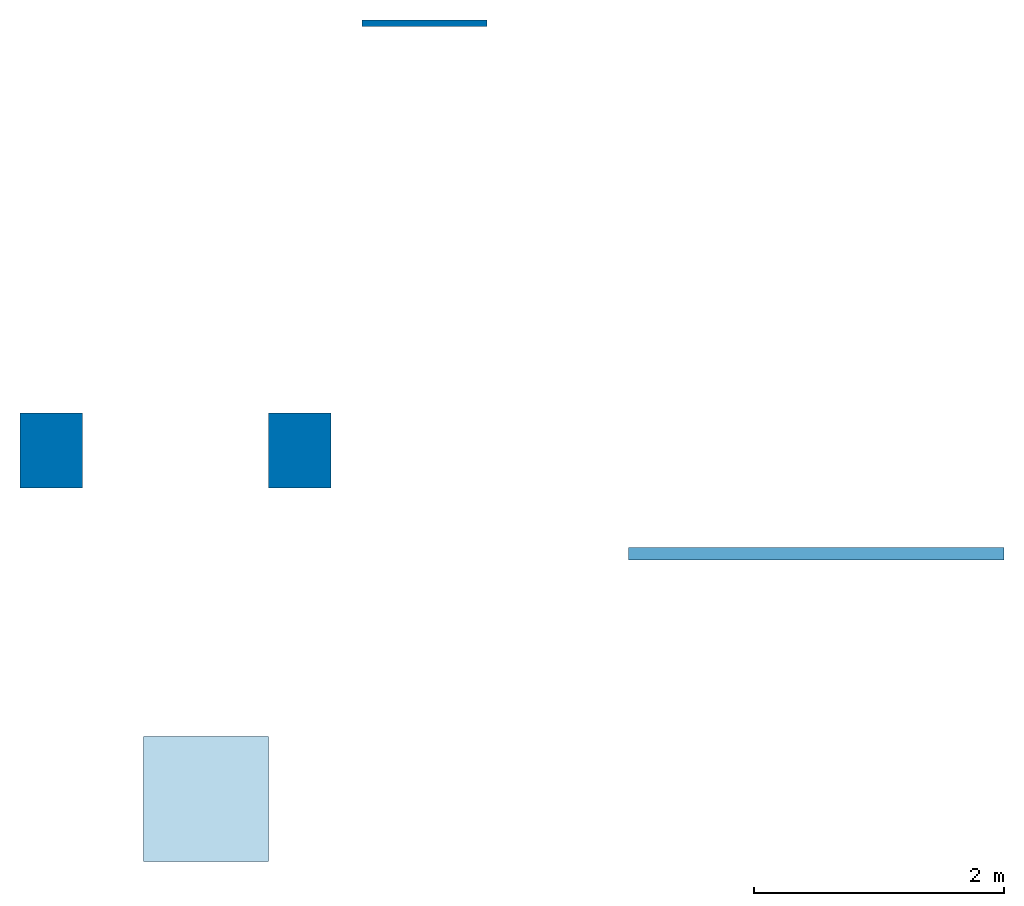
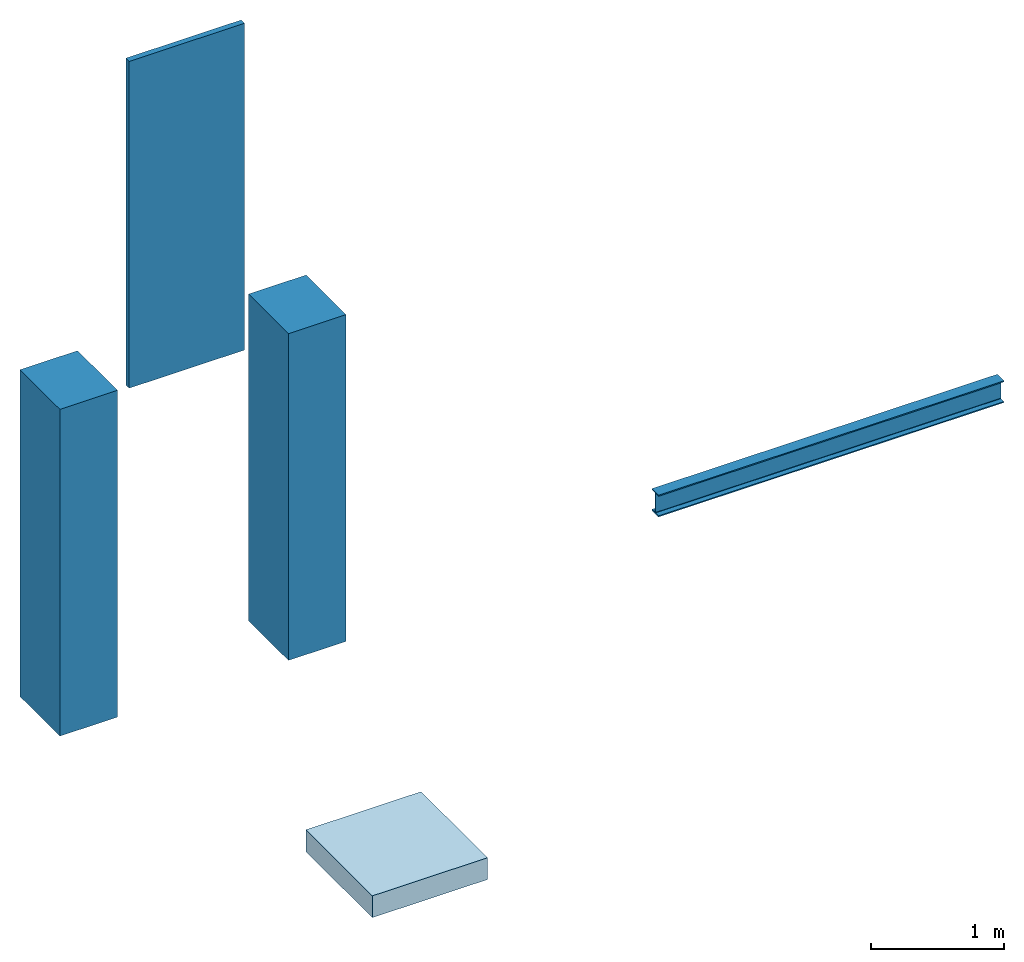
# One storey: 2 columns, 1 beam, 1 slab, 1 wall.
"""IFC4 building model written with IfcOpenShell, lengths in millimetres."""

from ifc_helpers import new_model, entity, si_unit, converted_unit, frame, origin_with_axes, origin_2d_with_axis, place, context, subcontext, project, spatial, indexed_curve, rectangle, i_section, outline, extrude, material, layer, layer_set, layer_usage, material_profile, profile_set, profile_usage, type_object, element, save


model = new_model("IFC4")

# Units and contexts
model_context = context("Model", 3, precision=1e-05, world=origin_with_axes())
plan_context = context("Plan", 2, precision=1e-05, world=origin_2d_with_axis())
body_context = subcontext(model_context, "Body", "Model", "MODEL_VIEW")
ifc_project = project(units=[si_unit("VOLUMEUNIT", "CUBIC_METRE"), si_unit("LENGTHUNIT", "METRE", prefix="MILLI"), converted_unit("PLANEANGLEUNIT", "degree", entity("IfcReal", 0.0174532925199433), si_unit("PLANEANGLEUNIT", "RADIAN"), dimensions=[0, 0, 0, 0, 0, 0, 0]), si_unit("AREAUNIT", "SQUARE_METRE")], contexts=[model_context, plan_context])

# Site, building, storey
site_placement = place(None, origin_with_axes())
site = spatial("IfcSite", under=ifc_project, at=site_placement)
building_placement = place(site_placement, origin_with_axes())
building = spatial("IfcBuilding", under=site, at=building_placement, Name="Building")
storey_placement = place(building_placement, origin_with_axes())
storey = spatial("IfcBuildingStorey", under=building, at=storey_placement, Name="Storey")

# Columns
ifc_material = material(Name="Green")
ifc_material_profile_1 = material_profile(ifc_material, rectangle(XDim=500.0, YDim=600.0))
ifc_profile_set_1 = profile_set([ifc_material_profile_1])
ifc_profile_usage_1 = profile_usage(ifc_profile_set_1, cardinal=5)
column_type = type_object("IfcColumnType", Name="C1", PredefinedType="NOTDEFINED", material=ifc_profile_set_1)
column_1_placement = place(storey_placement, frame((-730.887413024902, 780.275821685791, 0.0), z_axis=(0.0, 0.0, 1.0), x_axis=(1.0, 0.0, 0.0)))
element("IfcColumn", 1, at=column_1_placement, inside=storey, type_object=column_type, material=ifc_profile_usage_1, Name="Column", context=body_context, shape_type="SweptSolid", body=[
    extrude(rectangle(XDim=500.0, YDim=600.0), origin_with_axes(), (0.0, 0.0, 1.0), 3000.0),
])
ifc_profile_usage_2 = profile_usage(ifc_profile_set_1, cardinal=5)
column_2_placement = place(storey_placement, frame((-2715.92807769775, 780.275821685791, 0.0), z_axis=(0.0, 0.0, 1.0), x_axis=(1.0, 0.0, 0.0)))
element("IfcColumn", 2, at=column_2_placement, inside=storey, type_object=column_type, material=ifc_profile_usage_2, Name="Column", context=body_context, shape_type="SweptSolid", body=[
    extrude(rectangle(XDim=500.0, YDim=600.0), origin_with_axes(), (0.0, 0.0, 1.0), 3000.0),
])

# Beam
ifc_material_profile_2 = material_profile(ifc_material, i_section(OverallWidth=100.0, OverallDepth=200.0, WebThickness=5.0, FlangeThickness=10.0, FilletRadius=5.0))
ifc_profile_set_2 = profile_set([ifc_material_profile_2])
ifc_profile_usage_3 = profile_usage(ifc_profile_set_2, cardinal=5)
beam_type = type_object("IfcBeamType", Name="B1", PredefinedType="NOTDEFINED", material=ifc_profile_set_2)
beam_placement = place(storey_placement, frame((1899.37174320221, -46.2498664855957, 757.964909076691), z_axis=(0.999999999999994, -7.54979012640429e-08, 7.54979012640429e-08), x_axis=(7.54979012640431e-08, 0.999999999999997, 7.16093850883224e-15)))
element("IfcBeam", 3, at=beam_placement, inside=storey, type_object=beam_type, material=ifc_profile_usage_3, Name="Beam", context=body_context, shape_type="SweptSolid", body=[
    extrude(i_section(OverallWidth=100.0, OverallDepth=200.0, WebThickness=5.0, FlangeThickness=10.0, FilletRadius=5.0), origin_with_axes(), (0.0, 0.0, 1.0), 3000.0),
])

# Slab
ifc_layer_1 = layer(ifc_material, 200.0)
ifc_layer_set_1 = layer_set([ifc_layer_1])
ifc_layer_usage_1 = layer_usage(ifc_layer_set_1, "AXIS3", "POSITIVE", 0.0)
slab_type = type_object("IfcSlabType", Name="FLR150", PredefinedType="NOTDEFINED", material=ifc_layer_set_1)
slab_placement = place(storey_placement, frame((-1978.03401947021, -2508.0304145813, -200.000002980232), z_axis=(0.0, 0.0, 1.0), x_axis=(1.0, 0.0, 0.0)))
element("IfcSlab", 4, at=slab_placement, inside=storey, type_object=slab_type, material=ifc_layer_usage_1, Name="Slab", context=body_context, shape_type="SweptSolid", body=[
    extrude(outline(indexed_curve([(0.0, 0.0), (1000.0, 0.0), (1000.0, 1000.0), (0.0, 1000.0), (0.0, 0.0)])), None, (0.0, 0.0, 1.0), 200.0),
])

# Wall
ifc_layer_2 = layer(ifc_material, 50.0)
ifc_layer_set_2 = layer_set([ifc_layer_2])
ifc_layer_usage_2 = layer_usage(ifc_layer_set_2, "AXIS2", "POSITIVE", 0.0)
wall_type = type_object("IfcWallType", Name="WAL50", PredefinedType="NOTDEFINED", material=ifc_layer_set_2)
wall_placement = place(storey_placement, frame((-233.486175537109, 4170.19176483154, 0.0), z_axis=(0.0, 0.0, 1.0), x_axis=(1.0, 0.0, 0.0)))
element("IfcWall", 5, at=wall_placement, inside=storey, type_object=wall_type, material=ifc_layer_usage_2, Name="Wall", context=body_context, shape_type="SweptSolid", body=[
    extrude(outline(indexed_curve([(0.0, 0.0), (0.0, 50.0), (1000.0, 50.0), (1000.0, 0.0), (0.0, 0.0)], self_intersect=False)), origin_with_axes(), (0.0, 0.0, 1.0), 3000.0),
])

save(model, "model.ifc")
